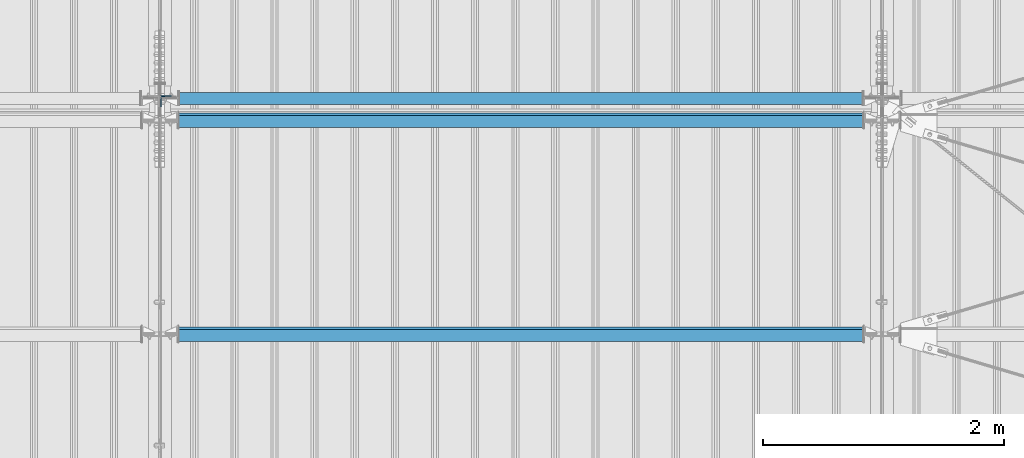
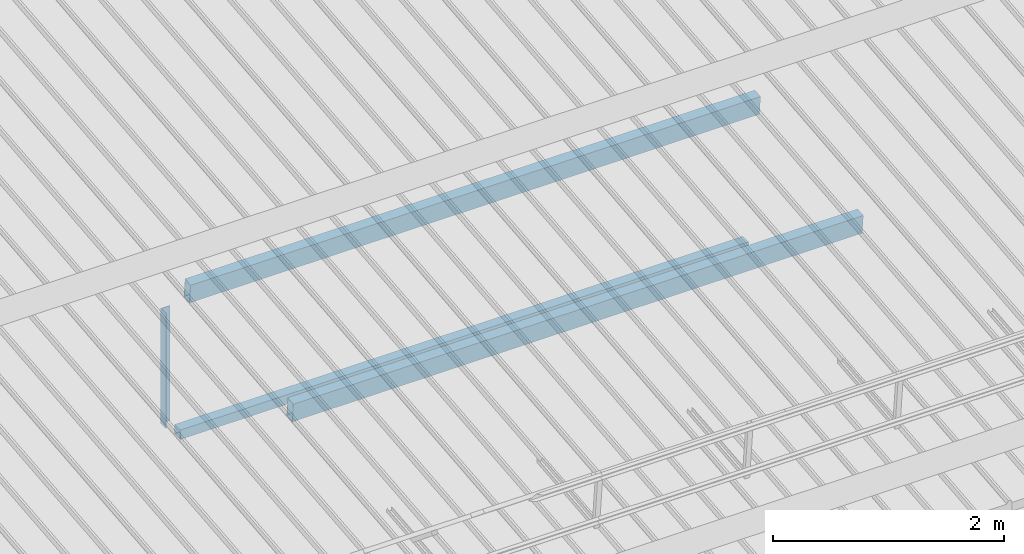
# One storey, part 272 of 709: 4 beams, 4 elements without a shape of their own.
"""IFC4 building model written with IfcOpenShell, lengths in millimetres."""

from ifc_helpers import new_model, si_unit, direction, frame, origin_with_axes, place, context, subcontext, project, spatial, polygons, material, element, aggregate, save


model = new_model("IFC4")

# Units and contexts
model_context = context("Model", 3, precision=0.2, world=origin_with_axes(), true_north=direction((0.0, 1.0)))
body_context = subcontext(model_context, "Body", "Model", "MODEL_VIEW")
ifc_project = project(units=[si_unit("LENGTHUNIT", "METRE", prefix="MILLI"), si_unit("AREAUNIT", "SQUARE_METRE"), si_unit("VOLUMEUNIT", "CUBIC_METRE"), si_unit("MASSUNIT", "GRAM", prefix="KILO"), si_unit("TIMEUNIT", "SECOND"), si_unit("PLANEANGLEUNIT", "RADIAN"), si_unit("SOLIDANGLEUNIT", "STERADIAN"), si_unit("THERMODYNAMICTEMPERATUREUNIT", "DEGREE_CELSIUS"), si_unit("LUMINOUSINTENSITYUNIT", "LUMEN")], contexts=[model_context])

# Site, building, storey
site_placement = place(None, origin_with_axes())
site = spatial("IfcSite", under=ifc_project, at=site_placement, CompositionType="ELEMENT")
building_placement = place(site_placement, origin_with_axes())
building = spatial("IfcBuilding", under=site, at=building_placement, Name="Undefined", CompositionType="ELEMENT")
storey_placement = place(building_placement, origin_with_axes())
storey = spatial("IfcBuildingStorey", under=building, at=storey_placement, Name="Undefined", CompositionType="ELEMENT", Elevation=0.0)

# Assembly, beam
assembly_1_placement = place(storey_placement, frame((34051.0, 5648.7, 7622.40002), z_axis=(0.0, -1.0, 0.0), x_axis=(0.0, 0.0, -1.0)))
assembly_1 = element("IfcElementAssembly", 1, at=assembly_1_placement, inside=storey)
ifc_material_1 = material(Name="C345-5", Category="STEEL")
beam_1_placement = place(assembly_1_placement, origin_with_axes())
beam_1 = element("IfcBeam", 2, at=beam_1_placement, material=ifc_material_1, ObjectType="436", context=body_context, shape_type="Tessellation", body=[
    polygons([(199.0491, -45.0, -45.0), (199.0491, 45.0, -45.0), (1412.4, 45.0, -45.0), (1412.4, -45.0, -45.0), (199.0491, 45.0, -39.0), (1412.4, 45.0, -39.0), (199.0491, -39.0, -39.0), (1412.4, -39.0, -39.0), (199.0491, -39.0, 45.0), (1412.4, -39.0, 45.0), (199.0491, -45.0, 45.0), (1412.4, -45.0, 45.0)], [[[1, 2, 3, 4]], [[2, 5, 6, 3]], [[5, 7, 8, 6]], [[7, 9, 10, 8]], [[9, 11, 12, 10]], [[11, 1, 4, 12]], [[6, 8, 10, 12, 4, 3]], [[11, 9, 7, 5, 2, 1]]], closed=True),
])
aggregate(assembly_1, [beam_1])

assembly_2_placement = place(storey_placement, frame((34000.0, 5673.0, 6074.30002), z_axis=(0.0, -1.0, 0.0), x_axis=(1.0, 0.0, 0.0)))
assembly_2 = element("IfcElementAssembly", 3, at=assembly_2_placement, inside=storey)
ifc_material_2 = material(Name="C355", Category="STEEL")
beam_2_placement = place(assembly_2_placement, origin_with_axes())
beam_2 = element("IfcBeam", 4, at=beam_2_placement, material=ifc_material_2, ObjectType="557", context=body_context, shape_type="Tessellation", body=[
    polygons([(162.0, -47.0, -47.0), (162.0, -47.0, 47.0), (5838.0, -47.0, 47.0), (5838.0, -47.0, -47.0), (162.0, 47.0, 47.0), (5838.0, 47.0, 47.0), (162.0, 47.0, -47.0), (5838.0, 47.0, -47.0), (162.0, -50.0, -50.0), (162.0, 50.0, -50.0), (5838.0, 50.0, -50.0), (5838.0, -50.0, -50.0), (162.0, 50.0, 50.0), (5838.0, 50.0, 50.0), (162.0, -50.0, 50.0), (5838.0, -50.0, 50.0)], [[[1, 2, 3, 4]], [[2, 5, 6, 3]], [[5, 7, 8, 6]], [[7, 1, 4, 8]], [[9, 10, 11, 12]], [[10, 13, 14, 11]], [[13, 15, 16, 14]], [[15, 9, 12, 16]], [[14, 16, 12, 11], [6, 8, 4, 3]], [[15, 13, 10, 9], [7, 5, 2, 1]]], closed=True),
])
aggregate(assembly_2, [beam_2])

assembly_3_placement = place(storey_placement, frame((34000.0, 3713.34988, 7499.7991), z_axis=(0.0, 0.9950371902, 0.099503719), x_axis=(1.0, 0.0, 0.0)))
assembly_3 = element("IfcElementAssembly", 5, at=assembly_3_placement, inside=storey)
beam_3_placement = place(assembly_3_placement, origin_with_axes())
beam_3 = element("IfcBeam", 6, at=beam_3_placement, material=ifc_material_2, ObjectType="579", context=body_context, shape_type="Tessellation", body=[
    polygons([(155.0, -96.0, -46.0), (155.0, -96.0, 46.0), (5845.0, -96.0, 46.0), (5845.0, -96.0, -46.0), (155.0, 96.0, 46.0), (5845.0, 96.0, 46.0), (155.0, 96.0, -46.0), (5845.0, 96.0, -46.0), (155.0, -100.0, -50.0), (155.0, 100.0, -50.0), (5845.0, 100.0, -50.0), (5845.0, -100.0, -50.0), (155.0, 100.0, 50.0), (5845.0, 100.0, 50.0), (155.0, -100.0, 50.0), (5845.0, -100.0, 50.0)], [[[1, 2, 3, 4]], [[2, 5, 6, 3]], [[5, 7, 8, 6]], [[7, 1, 4, 8]], [[9, 10, 11, 12]], [[10, 13, 14, 11]], [[13, 15, 16, 14]], [[15, 9, 12, 16]], [[14, 16, 12, 11], [6, 8, 4, 3]], [[15, 13, 10, 9], [7, 5, 2, 1]]], closed=True),
])
aggregate(assembly_3, [beam_3])

assembly_4_placement = place(storey_placement, frame((34000.0, 5490.04963, 7677.46908), z_axis=(0.0, 0.9950371902, 0.099503719), x_axis=(1.0, 0.0, 0.0)))
assembly_4 = element("IfcElementAssembly", 7, at=assembly_4_placement, inside=storey)
beam_4_placement = place(assembly_4_placement, origin_with_axes())
beam_4 = element("IfcBeam", 8, at=beam_4_placement, material=ifc_material_2, ObjectType="579", context=body_context, shape_type="Tessellation", body=[
    polygons([(155.0, -96.0, -46.0), (155.0, -96.0, 46.0), (5845.0, -96.0, 46.0), (5845.0, -96.0, -46.0), (155.0, 96.0, 46.0), (5845.0, 96.0, 46.0), (155.0, 96.0, -46.0), (5845.0, 96.0, -46.0), (155.0, -100.0, -50.0), (155.0, 100.0, -50.0), (5845.0, 100.0, -50.0), (5845.0, -100.0, -50.0), (155.0, 100.0, 50.0), (5845.0, 100.0, 50.0), (155.0, -100.0, 50.0), (5845.0, -100.0, 50.0)], [[[1, 2, 3, 4]], [[2, 5, 6, 3]], [[5, 7, 8, 6]], [[7, 1, 4, 8]], [[9, 10, 11, 12]], [[10, 13, 14, 11]], [[13, 15, 16, 14]], [[15, 9, 12, 16]], [[14, 16, 12, 11], [6, 8, 4, 3]], [[15, 13, 10, 9], [7, 5, 2, 1]]], closed=True),
])
aggregate(assembly_4, [beam_4])

save(model, "model.ifc")
